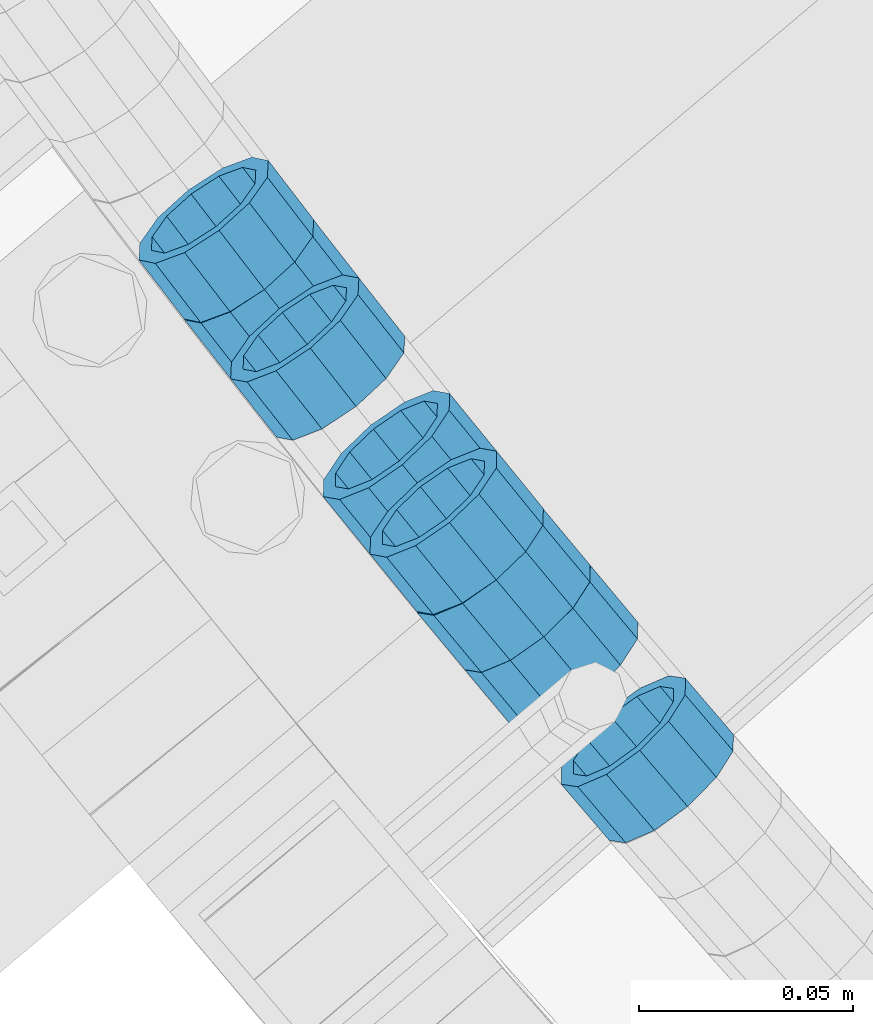
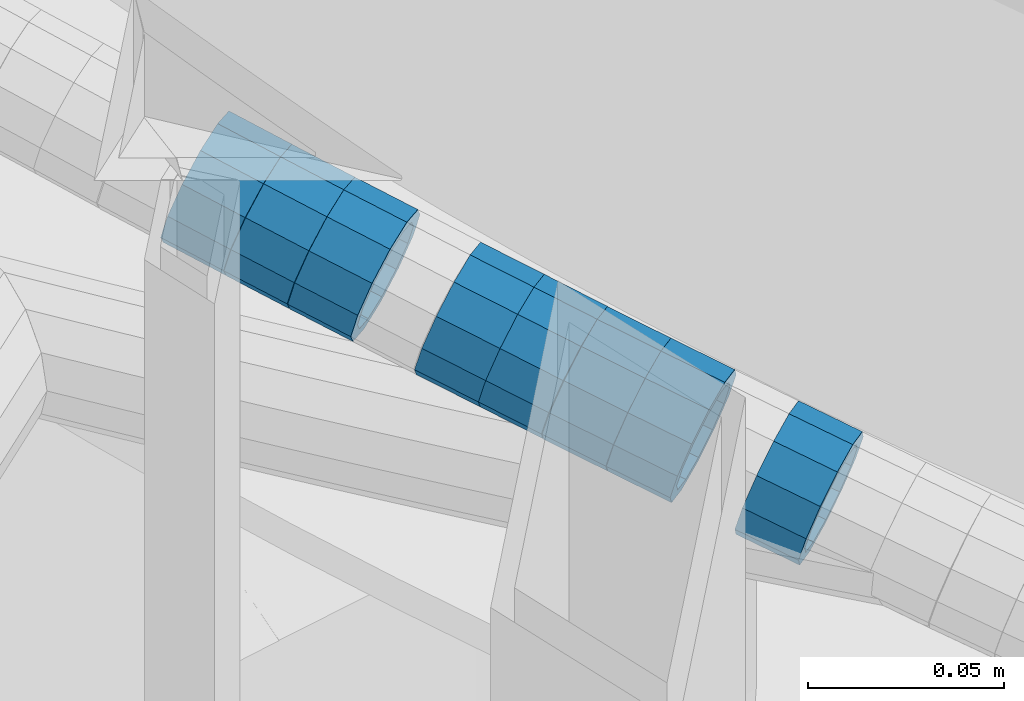
# One storey, part 653 of 975: 8 beams.
"""IFC2X3 building model written with IfcOpenShell, lengths in millimetres."""

from ifc_helpers import new_model, si_unit, frame, origin_with_axes, place, context, subcontext, project, spatial, faceted_brep, material, type_object, element, save


model = new_model("IFC2X3")

# Units and contexts
model_context = context("Model", 3, precision=1e-05, world=origin_with_axes())
body_context = subcontext(model_context, "Body", "Model", "MODEL_VIEW")
ifc_project = project(units=[si_unit("LENGTHUNIT", "METRE", prefix="MILLI"), si_unit("AREAUNIT", "SQUARE_METRE"), si_unit("VOLUMEUNIT", "CUBIC_METRE"), si_unit("MASSUNIT", "GRAM", prefix="KILO"), si_unit("TIMEUNIT", "SECOND"), si_unit("PLANEANGLEUNIT", "RADIAN"), si_unit("SOLIDANGLEUNIT", "STERADIAN"), si_unit("THERMODYNAMICTEMPERATUREUNIT", "DEGREE_CELSIUS"), si_unit("LUMINOUSINTENSITYUNIT", "LUMEN")], contexts=[model_context])

# Site, building, storey
site_placement = place(None, origin_with_axes())
site = spatial("IfcSite", under=ifc_project, at=site_placement, CompositionType="ELEMENT")
building_placement = place(site_placement, origin_with_axes())
building = spatial("IfcBuilding", under=site, at=building_placement, Name="Undefined", CompositionType="ELEMENT")
storey_placement = place(building_placement, origin_with_axes())
storey = spatial("IfcBuildingStorey", under=building, at=storey_placement, Name="Undefined", CompositionType="ELEMENT", Elevation=0.0)

# Beams
ifc_material = material()
beam_type = type_object("IfcBeamType", PredefinedType="NOTDEFINED")
beam_1_placement = place(storey_placement, frame((32539.4698831449, 1685.61706785686, 5036.67542537742), z_axis=(0.78591712047114, 0.618331852446849, 2.19472894968931e-10), x_axis=(0.588294059859827, -0.747738243821884, -0.307892217926674)))
element("IfcBeam", 1, at=beam_1_placement, inside=storey, type_object=beam_type, material=ifc_material, Name="WALL", context=body_context, shape_type="Brep", body=[
    faceted_brep([(-2.1246523829177e-07, -15.367000000002, 0.0), (-1.83998054126278e-07, -13.3082123799541, 7.68350000000009), (18.188182976899, -13.3082123799595, 7.68350000003556), (18.1881829768918, -15.3670000000002, 2.5465851649642e-11), (-1.06232619145885e-07, -7.68349999999919, 13.3082123799559), (18.1881829769027, -7.68350000000464, 13.3082123799904), (-3.63797880709171e-12, 3.63797880709171e-12, 15.3670000000002), (18.1881829769009, -5.45696821063757e-12, 15.3670000000311), (1.06225343188271e-07, 7.68350000000646, 13.3082123799559), (18.1881829768881, 7.68349999999373, 13.3082123799795), (1.8399441614747e-07, 13.308212379965, 7.68350000000009), (18.1881829768827, 13.3082123799486, 7.6835000000101), (2.12461600312963e-07, 15.3670000000093, 0.0), (18.1881829768718, 15.3669999999929, 0.0), (1.8399441614747e-07, 13.308212379965, -7.68350000000009), (18.1881829768645, 13.3082123799486, -7.68350000000646), (1.06225343188271e-07, 7.68350000000646, -13.3082123799559), (18.1881829768627, 7.68349999999555, -13.3082123799686), (-3.63797880709171e-12, 3.63797880709171e-12, -15.3670000000002), (18.1881829768681, -3.63797880709171e-12, -15.3670000000056), (-1.06232619145885e-07, -7.68349999999919, -13.3082123799559), (18.1881829768718, -7.683500000001, -13.3082123799504), (-1.83998054126278e-07, -13.3082123799541, -7.68350000000009), (18.1881829768809, -13.3082123799577, -7.68349999998463), (-2.63386027654633e-07, -19.0500000000029, 0.0), (-2.28097633225843e-07, -16.4977839420972, -9.52499999999964), (18.1881829768863, -16.4977839420953, -9.52499999998327), (18.1881829768954, -19.0500000000011, 3.27418092638254e-11), (-1.31691194837913e-07, -9.52500000000146, -16.4977839420935), (18.1881829768718, -9.52500000000327, -16.4977839420899), (-3.63797880709171e-12, 3.63797880709171e-12, -19.0500000000002), (18.1881829768608, -1.81898940354586e-12, -19.0500000000102), (1.31687556859106e-07, 9.52500000000509, -16.4977839420935), (18.1881829768554, 9.52499999999418, -16.4977839421081), (2.28097633225843e-07, 16.4977839421044, -9.52499999999964), (18.1881829768608, 16.4977839420862, -9.52500000001237), (2.63382389675826e-07, 19.0500000000138, 0.0), (18.1881829768681, 19.049999999992, 0.0), (2.28097633225843e-07, 16.4977839421044, 9.52499999999964), (18.1881829768809, 16.4977839420844, 9.52500000000873), (1.31687556859106e-07, 9.52500000000509, 16.4977839420935), (18.1881829768918, 9.52499999999236, 16.4977839421226), (-3.63797880709171e-12, 3.63797880709171e-12, 19.0500000000002), (18.1881829769027, -5.45696821063757e-12, 19.0500000000357), (-1.31691194837913e-07, -9.52500000000146, 16.4977839420935), (18.1881829769081, -9.52500000000327, 16.4977839421335), (-2.28097633225843e-07, -16.4977839420972, 9.52499999999964), (18.1881829769063, -16.4977839420953, 9.52500000004147)], [[[0, 1, 2, 3]], [[1, 4, 5, 2]], [[4, 6, 7, 5]], [[6, 8, 9, 7]], [[8, 10, 11, 9]], [[10, 12, 13, 11]], [[12, 14, 15, 13]], [[14, 16, 17, 15]], [[16, 18, 19, 17]], [[18, 20, 21, 19]], [[20, 22, 23, 21]], [[22, 0, 3, 23]], [[24, 25, 26, 27]], [[25, 28, 29, 26]], [[28, 30, 31, 29]], [[30, 32, 33, 31]], [[32, 34, 35, 33]], [[34, 36, 37, 35]], [[36, 38, 39, 37]], [[38, 40, 41, 39]], [[40, 42, 43, 41]], [[42, 44, 45, 43]], [[44, 46, 47, 45]], [[46, 24, 27, 47]], [[29, 31, 33, 35, 37, 39, 41, 43, 45, 47, 27, 26], [5, 7, 9, 11, 13, 15, 17, 19, 21, 23, 3, 2]], [[46, 44, 42, 40, 38, 36, 34, 32, 30, 28, 25, 24], [22, 20, 18, 16, 14, 12, 10, 8, 6, 4, 1, 0]]]),
])
beam_2_placement = place(storey_placement, frame((32528.7430865154, 1699.38527223965, 5042.39829657841), z_axis=(0.788111580005179, 0.615532401634341, -9.55405994318428e-11), x_axis=(0.584891602045426, -0.748879902058163, -0.311577769024189)))
element("IfcBeam", 2, at=beam_2_placement, inside=storey, type_object=beam_type, material=ifc_material, Name="WALL", context=body_context, shape_type="Brep", body=[
    faceted_brep([(-2.1246523829177e-07, -15.367000000002, 0.0), (-1.83998054126278e-07, -13.3082123799541, 7.68350000000009), (18.2939880835056, -13.3082123799395, 7.68349999996644), (18.2939880835038, -15.3669999999856, -2.5465851649642e-11), (-1.06232619145885e-07, -7.68349999999919, 13.3082123799559), (18.2939880835092, -7.68349999998463, 13.3082123799286), (-3.63797880709171e-12, 3.63797880709171e-12, 15.3670000000002), (18.2939880835129, 1.2732925824821e-11, 15.3669999999729), (1.06225343188271e-07, 7.68350000000646, 13.3082123799559), (18.2939880835183, 7.6835000000101, 13.3082123799395), (1.8399441614747e-07, 13.308212379965, 7.68350000000009), (18.2939880835256, 13.308212379965, 7.68349999998827), (2.12461600312963e-07, 15.3670000000093, 0.0), (18.2939880835256, 15.3670000000093, -3.63797880709171e-12), (1.8399441614747e-07, 13.308212379965, -7.68350000000009), (18.2939880835256, 13.308212379965, -7.68350000000282), (1.06225343188271e-07, 7.68350000000646, -13.3082123799559), (18.2939880835256, 7.6835000000101, -13.3082123799613), (-3.63797880709171e-12, 3.63797880709171e-12, -15.3670000000002), (18.293988083522, 1.09139364212751e-11, -15.3670000000129), (-1.06232619145885e-07, -7.68349999999919, -13.3082123799559), (18.2939880835129, -7.68349999998827, -13.3082123799722), (-1.83998054126278e-07, -13.3082123799541, -7.68350000000009), (18.2939880835092, -13.3082123799413, -7.68350000002465), (-2.63386027654633e-07, -19.0500000000029, 0.0), (-2.28097633225843e-07, -16.4977839420972, -9.52499999999964), (18.2939880835056, -16.497783942079, -9.52500000002328), (18.2939880835038, -19.0499999999847, -3.63797880709171e-11), (-1.31691194837913e-07, -9.52500000000146, -16.4977839420935), (18.2939880835165, -9.5249999999869, -16.4977839421081), (-3.63797880709171e-12, 3.63797880709171e-12, -19.0500000000002), (18.293988083522, 1.09139364212751e-11, -19.0500000000065), (1.31687556859106e-07, 9.52500000000509, -16.4977839420935), (18.2939880835256, 9.52500000000873, -16.4977839420935), (2.28097633225843e-07, 16.4977839421044, -9.52499999999964), (18.2939880835329, 16.4977839421008, -9.52499999999418), (2.63382389675826e-07, 19.0500000000138, 0.0), (18.2939880835311, 19.0500000000065, 0.0), (2.28097633225843e-07, 16.4977839421044, 9.52499999999964), (18.2939880835256, 16.4977839421044, 9.52499999999054), (1.31687556859106e-07, 9.52500000000509, 16.4977839420935), (18.2939880835183, 9.52500000001055, 16.4977839420753), (-3.63797880709171e-12, 3.63797880709171e-12, 19.0500000000002), (18.2939880835129, 1.2732925824821e-11, 19.0499999999738), (-1.31691194837913e-07, -9.52500000000146, 16.4977839420935), (18.2939880835056, -9.52499999998508, 16.4977839420608), (-2.28097633225843e-07, -16.4977839420972, 9.52499999999964), (18.2939880835056, -16.497783942079, 9.52499999996871)], [[[0, 1, 2, 3]], [[1, 4, 5, 2]], [[4, 6, 7, 5]], [[6, 8, 9, 7]], [[8, 10, 11, 9]], [[10, 12, 13, 11]], [[12, 14, 15, 13]], [[14, 16, 17, 15]], [[16, 18, 19, 17]], [[18, 20, 21, 19]], [[20, 22, 23, 21]], [[22, 0, 3, 23]], [[24, 25, 26, 27]], [[25, 28, 29, 26]], [[28, 30, 31, 29]], [[30, 32, 33, 31]], [[32, 34, 35, 33]], [[34, 36, 37, 35]], [[36, 38, 39, 37]], [[38, 40, 41, 39]], [[40, 42, 43, 41]], [[42, 44, 45, 43]], [[44, 46, 47, 45]], [[46, 24, 27, 47]], [[29, 31, 33, 35, 37, 39, 41, 43, 45, 47, 27, 26], [5, 7, 9, 11, 13, 15, 17, 19, 21, 23, 3, 2]], [[46, 44, 42, 40, 38, 36, 34, 32, 30, 28, 25, 24], [22, 20, 18, 16, 14, 12, 10, 8, 6, 4, 1, 0]]]),
])
beam_3_placement = place(storey_placement, frame((32518.1842834751, 1713.21023665222, 5048.09649719819), z_axis=(0.793051061872384, 0.609155163536421, 1.64813172887079e-10), x_axis=(0.578889356799218, -0.753648407738542, -0.311289559891988)))
element("IfcBeam", 3, at=beam_3_placement, inside=storey, type_object=beam_type, material=ifc_material, Name="WALL", context=body_context, shape_type="Brep", body=[
    faceted_brep([(-2.1246523829177e-07, -15.367000000002, 0.0), (-1.83998054126278e-07, -13.3082123799541, 7.68350000000009), (18.3098334236147, -13.308212379945, 7.68349999999919), (18.3098334236201, -15.3669999999893, 7.27595761418343e-12), (-1.06232619145885e-07, -7.68349999999919, 13.3082123799559), (18.3098334236092, -7.68349999998827, 13.3082123799468), (-3.63797880709171e-12, 3.63797880709171e-12, 15.3670000000002), (18.3098334236038, 1.2732925824821e-11, 15.3669999999802), (1.06225343188271e-07, 7.68350000000646, 13.3082123799559), (18.3098334235983, 7.68350000000828, 13.3082123799322), (1.8399441614747e-07, 13.308212379965, 7.68350000000009), (18.3098334235965, 13.3082123799632, 7.68349999997372), (2.12461600312963e-07, 15.3670000000093, 0.0), (18.3098334235983, 15.3670000000038, -2.18278728425503e-11), (1.8399441614747e-07, 13.308212379965, -7.68350000000009), (18.3098334236001, 13.3082123799577, -7.68350000001737), (1.06225343188271e-07, 7.68350000000646, -13.3082123799559), (18.3098334236092, 7.683500000001, -13.308212379965), (-3.63797880709171e-12, 3.63797880709171e-12, -15.3670000000002), (18.3098334236147, 1.81898940354586e-12, -15.3669999999984), (-1.06232619145885e-07, -7.68349999999919, -13.3082123799559), (18.3098334236165, -7.68349999999555, -13.3082123799504), (-1.83998054126278e-07, -13.3082123799541, -7.68350000000009), (18.3098334236183, -13.3082123799486, -7.68349999999191), (-2.63386027654633e-07, -19.0500000000029, 0.0), (-2.28097633225843e-07, -16.4977839420972, -9.52499999999964), (18.3098334236238, -16.4977839420862, -9.52499999999054), (18.309833423622, -19.0499999999902, 7.27595761418343e-12), (-1.31691194837913e-07, -9.52500000000146, -16.4977839420935), (18.3098334236165, -9.524999999996, -16.4977839420826), (-3.63797880709171e-12, 3.63797880709171e-12, -19.0500000000002), (18.3098334236147, 1.81898940354586e-12, -19.0499999999956), (1.31687556859106e-07, 9.52500000000509, -16.4977839420935), (18.3098334236038, 9.52499999999964, -16.4977839421008), (2.28097633225843e-07, 16.4977839421044, -9.52499999999964), (18.3098334236001, 16.4977839420953, -9.52500000001601), (2.63382389675826e-07, 19.0500000000138, 0.0), (18.3098334235929, 19.0500000000047, -2.5465851649642e-11), (2.28097633225843e-07, 16.4977839421044, 9.52499999999964), (18.3098334235947, 16.4977839421008, 9.52499999997235), (1.31687556859106e-07, 9.52500000000509, 16.4977839420935), (18.3098334235947, 9.52500000001055, 16.4977839420681), (-3.63797880709171e-12, 3.63797880709171e-12, 19.0500000000002), (18.3098334236001, 1.2732925824821e-11, 19.0499999999847), (-1.31691194837913e-07, -9.52500000000146, 16.4977839420935), (18.3098334236111, -9.5249999999869, 16.4977839420826), (-2.28097633225843e-07, -16.4977839420972, 9.52499999999964), (18.3098334236183, -16.4977839420808, 9.52500000000146)], [[[0, 1, 2, 3]], [[1, 4, 5, 2]], [[4, 6, 7, 5]], [[6, 8, 9, 7]], [[8, 10, 11, 9]], [[10, 12, 13, 11]], [[12, 14, 15, 13]], [[14, 16, 17, 15]], [[16, 18, 19, 17]], [[18, 20, 21, 19]], [[20, 22, 23, 21]], [[22, 0, 3, 23]], [[24, 25, 26, 27]], [[25, 28, 29, 26]], [[28, 30, 31, 29]], [[30, 32, 33, 31]], [[32, 34, 35, 33]], [[34, 36, 37, 35]], [[36, 38, 39, 37]], [[38, 40, 41, 39]], [[40, 42, 43, 41]], [[42, 44, 45, 43]], [[44, 46, 47, 45]], [[46, 24, 27, 47]], [[29, 31, 33, 35, 37, 39, 41, 43, 45, 47, 27, 26], [5, 7, 9, 11, 13, 15, 17, 19, 21, 23, 3, 2]], [[46, 44, 42, 40, 38, 36, 34, 32, 30, 28, 25, 24], [22, 20, 18, 16, 14, 12, 10, 8, 6, 4, 1, 0]]]),
])
beam_4_placement = place(storey_placement, frame((32593.842067907, 1618.1060816294, 5008.27356436387), z_axis=(0.767747910833277, 0.6407520155342, -8.10705387266352e-11), x_axis=(0.609687674977302, -0.730526673972784, -0.307590177988558)))
element("IfcBeam", 4, at=beam_4_placement, inside=storey, type_object=beam_type, material=ifc_material, Name="WALL", context=body_context, shape_type="Brep", body=[
    faceted_brep([(-2.1246523829177e-07, -15.367000000002, 0.0), (-1.83998054126278e-07, -13.3082123799541, 7.68350000000009), (18.2060429528137, -13.3082123799522, 7.68349999999555), (18.2060429528246, -15.3669999999966, 3.63797880709171e-12), (-1.06232619145885e-07, -7.68349999999919, 13.3082123799559), (18.2060429527992, -7.68349999999373, 13.3082123799359), (-3.63797880709171e-12, 3.63797880709171e-12, 15.3670000000002), (18.2060429527883, 5.45696821063757e-12, 15.3669999999656), (1.06225343188271e-07, 7.68350000000646, 13.3082123799559), (18.206042952781, 7.68350000000464, 13.308212379914), (1.8399441614747e-07, 13.308212379965, 7.68350000000009), (18.206042952781, 13.3082123799595, 7.68349999996281), (2.12461600312963e-07, 15.3670000000093, 0.0), (18.2060429527883, 15.3670000000038, -3.27418092638254e-11), (1.8399441614747e-07, 13.308212379965, -7.68350000000009), (18.2060429527992, 13.3082123799559, -7.68350000002101), (1.06225343188271e-07, 7.68350000000646, -13.3082123799559), (18.2060429528137, 7.683500000001, -13.3082123799613), (-3.63797880709171e-12, 3.63797880709171e-12, -15.3670000000002), (18.2060429528246, -1.81898940354586e-12, -15.3669999999947), (-1.06232619145885e-07, -7.68349999999919, -13.3082123799559), (18.2060429528319, -7.683500000001, -13.3082123799395), (-1.83998054126278e-07, -13.3082123799541, -7.68350000000009), (18.2060429528283, -13.3082123799559, -7.68349999998827), (-2.63386027654633e-07, -19.0500000000029, 0.0), (-2.28097633225843e-07, -16.4977839420972, -9.52499999999964), (18.2060429528356, -16.4977839420953, -9.52499999997599), (18.2060429528283, -19.0499999999975, 1.09139364212751e-11), (-1.31691194837913e-07, -9.52500000000146, -16.4977839420935), (18.2060429528356, -9.52500000000146, -16.4977839420717), (-3.63797880709171e-12, 3.63797880709171e-12, -19.0500000000002), (18.2060429528283, -1.81898940354586e-12, -19.0499999999884), (1.31687556859106e-07, 9.52500000000509, -16.4977839420935), (18.2060429528137, 9.52499999999964, -16.4977839421008), (2.28097633225843e-07, 16.4977839421044, -9.52499999999964), (18.2060429527955, 16.4977839420953, -9.52500000002328), (2.63382389675826e-07, 19.0500000000138, 0.0), (18.2060429527846, 19.0500000000029, -4.00177668780088e-11), (2.28097633225843e-07, 16.4977839421044, 9.52499999999964), (18.206042952781, 16.497783942099, 9.52499999995052), (1.31687556859106e-07, 9.52500000000509, 16.4977839420935), (18.2060429527774, 9.52500000000509, 16.4977839420426), (-3.63797880709171e-12, 3.63797880709171e-12, 19.0500000000002), (18.2060429527846, 5.45696821063757e-12, 19.0499999999629), (-1.31691194837913e-07, -9.52500000000146, 16.4977839420935), (18.2060429527992, -9.52499999999418, 16.4977839420681), (-2.28097633225843e-07, -16.4977839420972, 9.52499999999964), (18.2060429528174, -16.4977839420899, 9.52499999999782)], [[[0, 1, 2, 3]], [[1, 4, 5, 2]], [[4, 6, 7, 5]], [[6, 8, 9, 7]], [[8, 10, 11, 9]], [[10, 12, 13, 11]], [[12, 14, 15, 13]], [[14, 16, 17, 15]], [[16, 18, 19, 17]], [[18, 20, 21, 19]], [[20, 22, 23, 21]], [[22, 0, 3, 23]], [[24, 25, 26, 27]], [[25, 28, 29, 26]], [[28, 30, 31, 29]], [[30, 32, 33, 31]], [[32, 34, 35, 33]], [[34, 36, 37, 35]], [[36, 38, 39, 37]], [[38, 40, 41, 39]], [[40, 42, 43, 41]], [[42, 44, 45, 43]], [[44, 46, 47, 45]], [[46, 24, 27, 47]], [[29, 31, 33, 35, 37, 39, 41, 43, 45, 47, 27, 26], [5, 7, 9, 11, 13, 15, 17, 19, 21, 23, 3, 2]], [[46, 44, 42, 40, 38, 36, 34, 32, 30, 28, 25, 24], [22, 20, 18, 16, 14, 12, 10, 8, 6, 4, 1, 0]]]),
])
beam_5_placement = place(storey_placement, frame((32582.6815200419, 1631.47862997223, 5014.00438354065), z_axis=(0.767747910833277, 0.6407520155342, -8.10705387266352e-11), x_axis=(0.608651063702117, -0.729284607643017, -0.312550545846992)))
element("IfcBeam", 5, at=beam_5_placement, inside=storey, type_object=beam_type, material=ifc_material, Name="WALL", context=body_context, shape_type="Brep", body=[
    faceted_brep([(-2.1246523829177e-07, -15.367000000002, 0.0), (-1.83998054126278e-07, -13.3082123799541, 7.68350000000009), (18.2370502001177, -13.3082123799541, 7.6835000000392), (18.2370502001068, -15.3669999999984, 3.27418092638254e-11), (-1.06232619145885e-07, -7.68349999999919, 13.3082123799559), (18.2370502001177, -7.68349999999919, 13.3082123799977), (-3.63797880709171e-12, 3.63797880709171e-12, 15.3670000000002), (18.2370502001177, 3.63797880709171e-12, 15.3670000000384), (1.06225343188271e-07, 7.68350000000646, 13.3082123799559), (18.2370502001104, 7.68350000000282, 13.3082123799832), (1.8399441614747e-07, 13.308212379965, 7.68350000000009), (18.2370502000995, 13.3082123799577, 7.68350000001737), (2.12461600312963e-07, 15.3670000000093, 0.0), (18.2370502000886, 15.3670000000038, 1.09139364212751e-11), (1.8399441614747e-07, 13.308212379965, -7.68350000000009), (18.2370502000813, 13.3082123799577, -7.68349999999919), (1.06225343188271e-07, 7.68350000000646, -13.3082123799559), (18.2370502000776, 7.68350000000282, -13.3082123799577), (-3.63797880709171e-12, 3.63797880709171e-12, -15.3670000000002), (18.2370502000813, 3.63797880709171e-12, -15.3669999999984), (-1.06232619145885e-07, -7.68349999999919, -13.3082123799559), (18.2370502000849, -7.68349999999919, -13.3082123799468), (-1.83998054126278e-07, -13.3082123799541, -7.68350000000009), (18.2370502000958, -13.3082123799559, -7.683499999981), (-2.63386027654633e-07, -19.0500000000029, 0.0), (-2.28097633225843e-07, -16.4977839420972, -9.52499999999964), (18.2370502000995, -16.4977839420935, -9.52499999998327), (18.2370502001104, -19.0499999999993, 3.27418092638254e-11), (-1.31691194837913e-07, -9.52500000000146, -16.4977839420935), (18.2370502000886, -9.52499999999964, -16.4977839420899), (-3.63797880709171e-12, 3.63797880709171e-12, -19.0500000000002), (18.2370502000776, 0.0, -19.0500000000029), (1.31687556859106e-07, 9.52500000000509, -16.4977839420935), (18.237050200074, 9.52500000000146, -16.4977839421008), (2.28097633225843e-07, 16.4977839421044, -9.52499999999964), (18.2370502000776, 16.4977839420972, -9.52500000000509), (2.63382389675826e-07, 19.0500000000138, 0.0), (18.2370502000849, 19.0500000000029, 7.27595761418343e-12), (2.28097633225843e-07, 16.4977839421044, 9.52499999999964), (18.2370502000958, 16.4977839420972, 9.52500000001965), (1.31687556859106e-07, 9.52500000000509, 16.4977839420935), (18.2370502001104, 9.52500000000509, 16.4977839421263), (-3.63797880709171e-12, 3.63797880709171e-12, 19.0500000000002), (18.2370502001213, 3.63797880709171e-12, 19.0500000000393), (-1.31691194837913e-07, -9.52500000000146, 16.4977839420935), (18.2370502001249, -9.52499999999782, 16.4977839421408), (-2.28097633225843e-07, -16.4977839420972, 9.52499999999964), (18.2370502001177, -16.4977839420935, 9.52500000004511)], [[[0, 1, 2, 3]], [[1, 4, 5, 2]], [[4, 6, 7, 5]], [[6, 8, 9, 7]], [[8, 10, 11, 9]], [[10, 12, 13, 11]], [[12, 14, 15, 13]], [[14, 16, 17, 15]], [[16, 18, 19, 17]], [[18, 20, 21, 19]], [[20, 22, 23, 21]], [[22, 0, 3, 23]], [[24, 25, 26, 27]], [[25, 28, 29, 26]], [[28, 30, 31, 29]], [[30, 32, 33, 31]], [[32, 34, 35, 33]], [[34, 36, 37, 35]], [[36, 38, 39, 37]], [[38, 40, 41, 39]], [[40, 42, 43, 41]], [[42, 44, 45, 43]], [[44, 46, 47, 45]], [[46, 24, 27, 47]], [[29, 31, 33, 35, 37, 39, 41, 43, 45, 47, 27, 26], [5, 7, 9, 11, 13, 15, 17, 19, 21, 23, 3, 2]], [[46, 44, 42, 40, 38, 36, 34, 32, 30, 28, 25, 24], [22, 20, 18, 16, 14, 12, 10, 8, 6, 4, 1, 0]]]),
])
beam_6_placement = place(storey_placement, frame((32571.8296051631, 1644.93839295088, 5019.70950614035), z_axis=(0.775759711451968, 0.631028422567447, 2.5937788450392e-10), x_axis=(0.599244926048227, -0.73668642205932, -0.313366613025213)))
element("IfcBeam", 6, at=beam_6_placement, inside=storey, type_object=beam_type, material=ifc_material, Name="WALL", context=body_context, shape_type="Brep", body=[
    faceted_brep([(-2.1246523829177e-07, -15.367000000002, 0.0), (-1.83998054126278e-07, -13.3082123799541, 7.68350000000009), (18.188182976899, -13.3082123799595, 7.68350000003556), (18.1881829768918, -15.3670000000002, 2.5465851649642e-11), (-1.06232619145885e-07, -7.68349999999919, 13.3082123799559), (18.1881829769027, -7.68350000000464, 13.3082123799904), (-3.63797880709171e-12, 3.63797880709171e-12, 15.3670000000002), (18.1881829769009, -5.45696821063757e-12, 15.3670000000311), (1.06225343188271e-07, 7.68350000000646, 13.3082123799559), (18.1881829768881, 7.68349999999373, 13.3082123799795), (1.8399441614747e-07, 13.308212379965, 7.68350000000009), (18.1881829768827, 13.3082123799486, 7.6835000000101), (2.12461600312963e-07, 15.3670000000093, 0.0), (18.1881829768718, 15.3669999999929, 0.0), (1.8399441614747e-07, 13.308212379965, -7.68350000000009), (18.1881829768645, 13.3082123799486, -7.68350000000646), (1.06225343188271e-07, 7.68350000000646, -13.3082123799559), (18.1881829768627, 7.68349999999555, -13.3082123799686), (-3.63797880709171e-12, 3.63797880709171e-12, -15.3670000000002), (18.1881829768681, -3.63797880709171e-12, -15.3670000000056), (-1.06232619145885e-07, -7.68349999999919, -13.3082123799559), (18.1881829768718, -7.683500000001, -13.3082123799504), (-1.83998054126278e-07, -13.3082123799541, -7.68350000000009), (18.1881829768809, -13.3082123799577, -7.68349999998463), (-2.63386027654633e-07, -19.0500000000029, 0.0), (-2.28097633225843e-07, -16.4977839420972, -9.52499999999964), (18.1881829768863, -16.4977839420953, -9.52499999998327), (18.1881829768954, -19.0500000000011, 3.27418092638254e-11), (-1.31691194837913e-07, -9.52500000000146, -16.4977839420935), (18.1881829768718, -9.52500000000327, -16.4977839420899), (-3.63797880709171e-12, 3.63797880709171e-12, -19.0500000000002), (18.1881829768608, -1.81898940354586e-12, -19.0500000000102), (1.31687556859106e-07, 9.52500000000509, -16.4977839420935), (18.1881829768554, 9.52499999999418, -16.4977839421081), (2.28097633225843e-07, 16.4977839421044, -9.52499999999964), (18.1881829768608, 16.4977839420862, -9.52500000001237), (2.63382389675826e-07, 19.0500000000138, 0.0), (18.1881829768681, 19.049999999992, 0.0), (2.28097633225843e-07, 16.4977839421044, 9.52499999999964), (18.1881829768809, 16.4977839420844, 9.52500000000873), (1.31687556859106e-07, 9.52500000000509, 16.4977839420935), (18.1881829768918, 9.52499999999236, 16.4977839421226), (-3.63797880709171e-12, 3.63797880709171e-12, 19.0500000000002), (18.1881829769027, -5.45696821063757e-12, 19.0500000000357), (-1.31691194837913e-07, -9.52500000000146, 16.4977839420935), (18.1881829769081, -9.52500000000327, 16.4977839421335), (-2.28097633225843e-07, -16.4977839420972, 9.52499999999964), (18.1881829769063, -16.4977839420953, 9.52500000004147)], [[[0, 1, 2, 3]], [[1, 4, 5, 2]], [[4, 6, 7, 5]], [[6, 8, 9, 7]], [[8, 10, 11, 9]], [[10, 12, 13, 11]], [[12, 14, 15, 13]], [[14, 16, 17, 15]], [[16, 18, 19, 17]], [[18, 20, 21, 19]], [[20, 22, 23, 21]], [[22, 0, 3, 23]], [[24, 25, 26, 27]], [[25, 28, 29, 26]], [[28, 30, 31, 29]], [[30, 32, 33, 31]], [[32, 34, 35, 33]], [[34, 36, 37, 35]], [[36, 38, 39, 37]], [[38, 40, 41, 39]], [[40, 42, 43, 41]], [[42, 44, 45, 43]], [[44, 46, 47, 45]], [[46, 24, 27, 47]], [[29, 31, 33, 35, 37, 39, 41, 43, 45, 47, 27, 26], [5, 7, 9, 11, 13, 15, 17, 19, 21, 23, 3, 2]], [[46, 44, 42, 40, 38, 36, 34, 32, 30, 28, 25, 24], [22, 20, 18, 16, 14, 12, 10, 8, 6, 4, 1, 0]]]),
])
beam_7_placement = place(storey_placement, frame((32560.8532626798, 1658.40150424575, 5025.39519546999), z_axis=(0.775234985750461, 0.631672950876071, 2.01480361283757e-11), x_axis=(0.600331513874825, -0.736770494846379, -0.311080875935154)))
element("IfcBeam", 7, at=beam_7_placement, inside=storey, type_object=beam_type, material=ifc_material, Name="WALL", context=body_context, shape_type="Brep", body=[
    faceted_brep([(-2.1246523829177e-07, -15.367000000002, 0.0), (-1.83998054126278e-07, -13.3082123799541, 7.68350000000009), (18.3232093259357, -13.3082123799704, 7.68350000004648), (18.3232093259248, -15.3670000000111, 3.63797880709171e-11), (-1.06232619145885e-07, -7.68349999999919, 13.3082123799559), (18.3232093259394, -7.68350000001556, 13.308212380005), (-3.63797880709171e-12, 3.63797880709171e-12, 15.3670000000002), (18.3232093259285, -1.2732925824821e-11, 15.367000000042), (1.06225343188271e-07, 7.68350000000646, 13.3082123799559), (18.3232093259139, 7.68349999999555, 13.3082123799868), (1.8399441614747e-07, 13.308212379965, 7.68350000000009), (18.3232093258957, 13.3082123799595, 7.6835000000101), (2.12461600312963e-07, 15.3670000000093, 0.0), (18.3232093258812, 15.3670000000111, -7.27595761418343e-12), (1.8399441614747e-07, 13.308212379965, -7.68350000000009), (18.3232093258666, 13.3082123799704, -7.68350000001737), (1.06225343188271e-07, 7.68350000000646, -13.3082123799559), (18.3232093258666, 7.68350000001556, -13.3082123799722), (-3.63797880709171e-12, 3.63797880709171e-12, -15.3670000000002), (18.3232093258703, 1.2732925824821e-11, -15.3670000000166), (-1.06232619145885e-07, -7.68349999999919, -13.3082123799559), (18.3232093258885, -7.68349999999555, -13.3082123799577), (-1.83998054126278e-07, -13.3082123799541, -7.68350000000009), (18.323209325903, -13.3082123799577, -7.68349999998463), (-2.63386027654633e-07, -19.0500000000029, 0.0), (-2.28097633225843e-07, -16.4977839420972, -9.52499999999964), (18.3232093259066, -16.4977839420972, -9.52499999998327), (18.3232093259285, -19.050000000012, 4.00177668780088e-11), (-1.31691194837913e-07, -9.52500000000146, -16.4977839420935), (18.3232093258812, -9.52499999999236, -16.4977839421008), (-3.63797880709171e-12, 3.63797880709171e-12, -19.0500000000002), (18.3232093258666, 1.63709046319127e-11, -19.0500000000211), (1.31687556859106e-07, 9.52500000000509, -16.4977839420935), (18.3232093258557, 9.52500000002146, -16.4977839421226), (2.28097633225843e-07, 16.4977839421044, -9.52499999999964), (18.3232093258557, 16.4977839421135, -9.52500000002692), (2.63382389675826e-07, 19.0500000000138, 0.0), (18.3232093258703, 19.0500000000138, -1.09139364212751e-11), (2.28097633225843e-07, 16.4977839421044, 9.52499999999964), (18.3232093258921, 16.497783942099, 9.52500000000873), (1.31687556859106e-07, 9.52500000000509, 16.4977839420935), (18.3232093259176, 9.52499999999418, 16.4977839421263), (-3.63797880709171e-12, 3.63797880709171e-12, 19.0500000000002), (18.3232093259357, -1.2732925824821e-11, 19.0500000000466), (-1.31691194837913e-07, -9.52500000000146, 16.4977839420935), (18.3232093259467, -9.52500000001783, 16.4977839421481), (-2.28097633225843e-07, -16.4977839420972, 9.52499999999964), (18.323209325943, -16.4977839421135, 9.52500000005239)], [[[0, 1, 2, 3]], [[1, 4, 5, 2]], [[4, 6, 7, 5]], [[6, 8, 9, 7]], [[8, 10, 11, 9]], [[10, 12, 13, 11]], [[12, 14, 15, 13]], [[14, 16, 17, 15]], [[16, 18, 19, 17]], [[18, 20, 21, 19]], [[20, 22, 23, 21]], [[22, 0, 3, 23]], [[24, 25, 26, 27]], [[25, 28, 29, 26]], [[28, 30, 31, 29]], [[30, 32, 33, 31]], [[32, 34, 35, 33]], [[34, 36, 37, 35]], [[36, 38, 39, 37]], [[38, 40, 41, 39]], [[40, 42, 43, 41]], [[42, 44, 45, 43]], [[44, 46, 47, 45]], [[46, 24, 27, 47]], [[29, 31, 33, 35, 37, 39, 41, 43, 45, 47, 27, 26], [5, 7, 9, 11, 13, 15, 17, 19, 21, 23, 3, 2]], [[46, 44, 42, 40, 38, 36, 34, 32, 30, 28, 25, 24], [22, 20, 18, 16, 14, 12, 10, 8, 6, 4, 1, 0]]]),
])
beam_8_placement = place(storey_placement, frame((32616.1712031976, 1591.58175569014, 4996.98236231104), z_axis=(0.760075120768286, 0.64983521818156, 9.37625372898767e-11), x_axis=(0.618030397885649, -0.722874839866234, -0.309015198942824)))
element("IfcBeam", 8, at=beam_8_placement, inside=storey, type_object=beam_type, material=ifc_material, Name="WALL", context=body_context, shape_type="Brep", body=[
    faceted_brep([(-2.1246523829177e-07, -15.367000000002, 0.0), (-1.83998054126278e-07, -13.3082123799541, 7.68350000000009), (18.1220859726709, -13.3082123799632, 7.68350000001737), (18.1220859726709, -15.3670000000056, 1.45519152283669e-11), (-1.06232619145885e-07, -7.68349999999919, 13.3082123799559), (18.1220859726709, -7.68350000000646, 13.3082123799722), (-3.63797880709171e-12, 3.63797880709171e-12, 15.3670000000002), (18.1220859726782, -9.09494701772928e-12, 15.3670000000202), (1.06225343188271e-07, 7.68350000000646, 13.3082123799559), (18.1220859726782, 7.68349999999009, 13.3082123799795), (1.8399441614747e-07, 13.308212379965, 7.68350000000009), (18.1220859726782, 13.3082123799431, 7.68350000002101), (2.12461600312963e-07, 15.3670000000093, 0.0), (18.1220859726818, 15.3669999999875, 2.5465851649642e-11), (1.8399441614747e-07, 13.308212379965, -7.68350000000009), (18.1220859726818, 13.3082123799431, -7.68349999997736), (1.06225343188271e-07, 7.68350000000646, -13.3082123799559), (18.1220859726782, 7.68349999998827, -13.3082123799322), (-3.63797880709171e-12, 3.63797880709171e-12, -15.3670000000002), (18.1220859726745, -1.09139364212751e-11, -15.3669999999838), (-1.06232619145885e-07, -7.68349999999919, -13.3082123799559), (18.1220859726745, -7.6835000000101, -13.3082123799359), (-1.83998054126278e-07, -13.3082123799541, -7.68350000000009), (18.1220859726709, -13.3082123799632, -7.68349999998463), (-2.63386027654633e-07, -19.0500000000029, 0.0), (-2.28097633225843e-07, -16.4977839420972, -9.52499999999964), (18.1220859726673, -16.4977839421008, -9.5249999999869), (18.1220859726709, -19.0500000000065, 1.45519152283669e-11), (-1.31691194837913e-07, -9.52500000000146, -16.4977839420935), (18.1220859726709, -9.52500000000873, -16.4977839420753), (-3.63797880709171e-12, 3.63797880709171e-12, -19.0500000000002), (18.1220859726782, -1.09139364212751e-11, -19.0499999999811), (1.31687556859106e-07, 9.52500000000509, -16.4977839420935), (18.1220859726782, 9.5249999999869, -16.4977839420717), (2.28097633225843e-07, 16.4977839421044, -9.52499999999964), (18.1220859726782, 16.4977839420808, -9.52499999997599), (2.63382389675826e-07, 19.0500000000138, 0.0), (18.1220859726818, 19.0499999999884, 2.18278728425503e-11), (2.28097633225843e-07, 16.4977839421044, 9.52499999999964), (18.1220859726818, 16.4977839420826, 9.52500000002692), (1.31687556859106e-07, 9.52500000000509, 16.4977839420935), (18.1220859726818, 9.52499999999054, 16.497783942119), (-3.63797880709171e-12, 3.63797880709171e-12, 19.0500000000002), (18.1220859726782, -7.27595761418343e-12, 19.0500000000211), (-1.31691194837913e-07, -9.52500000000146, 16.4977839420935), (18.1220859726745, -9.52500000000509, 16.4977839421117), (-2.28097633225843e-07, -16.4977839420972, 9.52499999999964), (18.1220859726709, -16.497783942099, 9.52500000001237)], [[[0, 1, 2, 3]], [[1, 4, 5, 2]], [[4, 6, 7, 5]], [[6, 8, 9, 7]], [[8, 10, 11, 9]], [[10, 12, 13, 11]], [[12, 14, 15, 13]], [[14, 16, 17, 15]], [[16, 18, 19, 17]], [[18, 20, 21, 19]], [[20, 22, 23, 21]], [[22, 0, 3, 23]], [[24, 25, 26, 27]], [[25, 28, 29, 26]], [[28, 30, 31, 29]], [[30, 32, 33, 31]], [[32, 34, 35, 33]], [[34, 36, 37, 35]], [[36, 38, 39, 37]], [[38, 40, 41, 39]], [[40, 42, 43, 41]], [[42, 44, 45, 43]], [[44, 46, 47, 45]], [[46, 24, 27, 47]], [[29, 31, 33, 35, 37, 39, 41, 43, 45, 47, 27, 26], [5, 7, 9, 11, 13, 15, 17, 19, 21, 23, 3, 2]], [[46, 44, 42, 40, 38, 36, 34, 32, 30, 28, 25, 24], [22, 20, 18, 16, 14, 12, 10, 8, 6, 4, 1, 0]]]),
])

save(model, "model.ifc")
